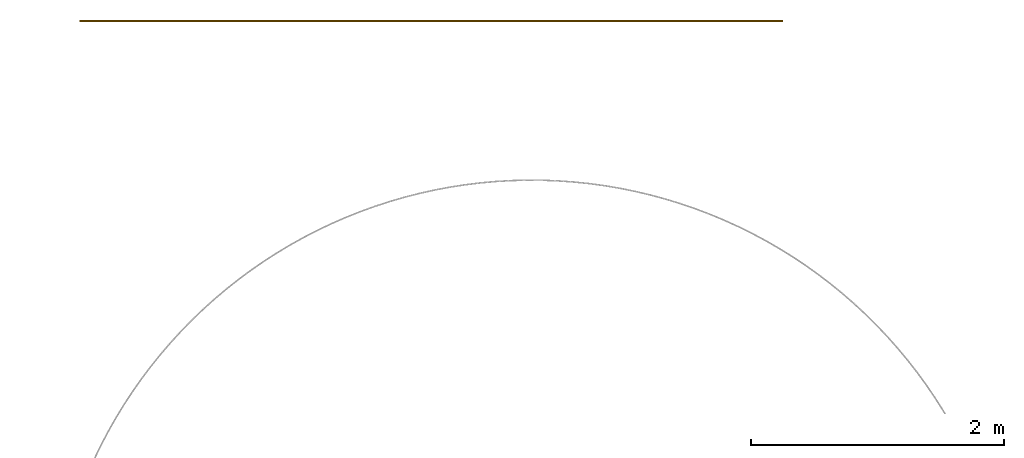
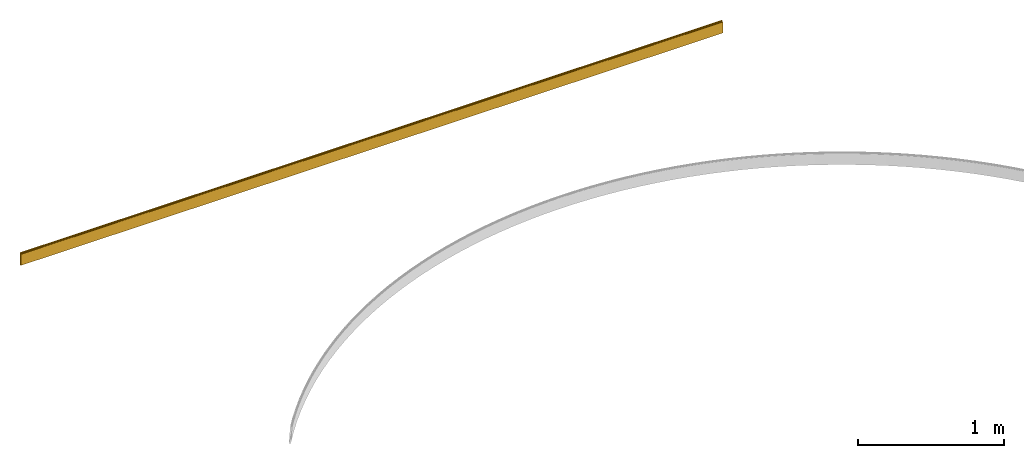
# One storey, part 2 of 2: 1 covering.
"""IFC2X3 building model written with IfcOpenShell, lengths in feet."""

from ifc_helpers import new_model, entity, si_unit, converted_unit, derived_unit, money_unit, direction, frame, frame_2d, origin_with_axes, place, context, subcontext, project, spatial, polyline, circle_curve, parameter, trimmed, segment, composite_curve, outline, extrude, material, type_object, element, save


model = new_model("IFC2X3")

# Units and contexts
model_context = context("Model", 3, precision=1e-05, world=origin_with_axes(), true_north=direction((0.0, 1.0)))
body_context = subcontext(model_context, "Body", "Model", "MODEL_VIEW", scale=1.0)
ifc_project = project(units=[converted_unit("LENGTHUNIT", "foot", entity("IfcReal", 30.48), si_unit("LENGTHUNIT", "METRE", prefix="CENTI"), dimensions=[1, 0, 0, 0, 0, 0, 0]), si_unit("AREAUNIT", "SQUARE_METRE"), si_unit("VOLUMEUNIT", "CUBIC_METRE"), si_unit("ABSORBEDDOSEUNIT", "GRAY"), si_unit("AMOUNTOFSUBSTANCEUNIT", "MOLE"), si_unit("DOSEEQUIVALENTUNIT", "SIEVERT"), si_unit("ELECTRICCAPACITANCEUNIT", "FARAD"), si_unit("ELECTRICCHARGEUNIT", "COULOMB"), si_unit("ELECTRICCONDUCTANCEUNIT", "SIEMENS"), si_unit("ELECTRICCURRENTUNIT", "AMPERE"), si_unit("ELECTRICRESISTANCEUNIT", "OHM"), si_unit("ELECTRICVOLTAGEUNIT", "VOLT"), si_unit("ENERGYUNIT", "JOULE"), si_unit("FORCEUNIT", "NEWTON"), si_unit("FREQUENCYUNIT", "HERTZ"), si_unit("ILLUMINANCEUNIT", "LUX"), si_unit("INDUCTANCEUNIT", "HENRY"), si_unit("LUMINOUSFLUXUNIT", "LUMEN"), si_unit("LUMINOUSINTENSITYUNIT", "CANDELA"), si_unit("MAGNETICFLUXDENSITYUNIT", "TESLA"), si_unit("MAGNETICFLUXUNIT", "WEBER"), si_unit("MASSUNIT", "GRAM"), converted_unit("PLANEANGLEUNIT", "degree", entity("IfcReal", 0.0174532925199433), si_unit("PLANEANGLEUNIT", "RADIAN"), dimensions=[0, 0, 0, 0, 0, 0, 0]), si_unit("POWERUNIT", "WATT"), si_unit("PRESSUREUNIT", "PASCAL"), si_unit("RADIOACTIVITYUNIT", "BECQUEREL"), si_unit("SOLIDANGLEUNIT", "STERADIAN"), si_unit("THERMODYNAMICTEMPERATUREUNIT", "KELVIN"), si_unit("TIMEUNIT", "SECOND"), derived_unit("ACCELERATIONUNIT", [(converted_unit("LENGTHUNIT", "foot", entity("IfcReal", 30.48), si_unit("LENGTHUNIT", "METRE", prefix="CENTI"), dimensions=[1, 0, 0, 0, 0, 0, 0]), 1), (si_unit("TIMEUNIT", "SECOND"), -2)]), derived_unit("ANGULARVELOCITYUNIT", [(converted_unit("PLANEANGLEUNIT", "degree", entity("IfcReal", 0.0174532925199433), si_unit("PLANEANGLEUNIT", "RADIAN"), dimensions=[0, 0, 0, 0, 0, 0, 0]), 1), (si_unit("TIMEUNIT", "SECOND"), -1)]), derived_unit("CURVATUREUNIT", [(converted_unit("PLANEANGLEUNIT", "degree", entity("IfcReal", 0.0174532925199433), si_unit("PLANEANGLEUNIT", "RADIAN"), dimensions=[0, 0, 0, 0, 0, 0, 0]), 1), (converted_unit("LENGTHUNIT", "foot", entity("IfcReal", 30.48), si_unit("LENGTHUNIT", "METRE", prefix="CENTI"), dimensions=[1, 0, 0, 0, 0, 0, 0]), -1)]), derived_unit("DYNAMICVISCOSITYUNIT", [(si_unit("PRESSUREUNIT", "PASCAL"), 1), (si_unit("TIMEUNIT", "SECOND"), 1)]), derived_unit("HEATFLUXDENSITYUNIT", [(si_unit("POWERUNIT", "WATT"), 1), (converted_unit("LENGTHUNIT", "foot", entity("IfcReal", 30.48), si_unit("LENGTHUNIT", "METRE", prefix="CENTI"), dimensions=[1, 0, 0, 0, 0, 0, 0]), -2)]), derived_unit("HEATINGVALUEUNIT", [(si_unit("ENERGYUNIT", "JOULE"), 1), (si_unit("MASSUNIT", "GRAM"), -1)]), derived_unit("INTEGERCOUNTRATEUNIT", [(si_unit("TIMEUNIT", "SECOND"), -1)]), derived_unit("IONCONCENTRATIONUNIT", [(si_unit("MASSUNIT", "GRAM"), 1), (si_unit("VOLUMEUNIT", "CUBIC_METRE"), -1)]), derived_unit("ISOTHERMALMOISTURECAPACITYUNIT", [(si_unit("VOLUMEUNIT", "CUBIC_METRE"), 1), (si_unit("MASSUNIT", "GRAM"), -1)]), derived_unit("KINEMATICVISCOSITYUNIT", [(si_unit("AREAUNIT", "SQUARE_METRE"), 1), (si_unit("TIMEUNIT", "SECOND"), -1)]), derived_unit("LINEARFORCEUNIT", [(si_unit("FORCEUNIT", "NEWTON"), 1), (converted_unit("LENGTHUNIT", "foot", entity("IfcReal", 30.48), si_unit("LENGTHUNIT", "METRE", prefix="CENTI"), dimensions=[1, 0, 0, 0, 0, 0, 0]), -1)]), derived_unit("LINEARMOMENTUNIT", [(si_unit("FORCEUNIT", "NEWTON"), 1), (converted_unit("LENGTHUNIT", "foot", entity("IfcReal", 30.48), si_unit("LENGTHUNIT", "METRE", prefix="CENTI"), dimensions=[1, 0, 0, 0, 0, 0, 0]), -1)]), derived_unit("LINEARSTIFFNESSUNIT", [(si_unit("FORCEUNIT", "NEWTON"), 1), (converted_unit("LENGTHUNIT", "foot", entity("IfcReal", 30.48), si_unit("LENGTHUNIT", "METRE", prefix="CENTI"), dimensions=[1, 0, 0, 0, 0, 0, 0]), -1)]), derived_unit("LINEARVELOCITYUNIT", [(converted_unit("LENGTHUNIT", "foot", entity("IfcReal", 30.48), si_unit("LENGTHUNIT", "METRE", prefix="CENTI"), dimensions=[1, 0, 0, 0, 0, 0, 0]), 1), (si_unit("TIMEUNIT", "SECOND"), -1)]), derived_unit("LUMINOUSINTENSITYDISTRIBUTIONUNIT", [(si_unit("LUMINOUSINTENSITYUNIT", "CANDELA"), 1), (si_unit("LUMINOUSFLUXUNIT", "LUMEN"), -1)]), derived_unit("MASSDENSITYUNIT", [(si_unit("MASSUNIT", "GRAM"), 1), (si_unit("VOLUMEUNIT", "CUBIC_METRE"), -1)]), derived_unit("MASSFLOWRATEUNIT", [(si_unit("MASSUNIT", "GRAM"), 1), (si_unit("TIMEUNIT", "SECOND"), -1)]), derived_unit("MASSPERLENGTHUNIT", [(si_unit("MASSUNIT", "GRAM"), 1), (converted_unit("LENGTHUNIT", "foot", entity("IfcReal", 30.48), si_unit("LENGTHUNIT", "METRE", prefix="CENTI"), dimensions=[1, 0, 0, 0, 0, 0, 0]), -1)]), derived_unit("MODULUSOFELASTICITYUNIT", [(si_unit("FORCEUNIT", "NEWTON"), 1), (si_unit("AREAUNIT", "SQUARE_METRE"), -1)]), derived_unit("MODULUSOFLINEARSUBGRADEREACTIONUNIT", [(si_unit("FORCEUNIT", "NEWTON"), 1), (converted_unit("LENGTHUNIT", "foot", entity("IfcReal", 30.48), si_unit("LENGTHUNIT", "METRE", prefix="CENTI"), dimensions=[1, 0, 0, 0, 0, 0, 0]), -2)]), derived_unit("MODULUSOFROTATIONALSUBGRADEREACTIONUNIT", [(si_unit("FORCEUNIT", "NEWTON"), 1), (converted_unit("LENGTHUNIT", "foot", entity("IfcReal", 30.48), si_unit("LENGTHUNIT", "METRE", prefix="CENTI"), dimensions=[1, 0, 0, 0, 0, 0, 0]), 1)]), derived_unit("MODULUSOFSUBGRADEREACTIONUNIT", [(si_unit("FORCEUNIT", "NEWTON"), 1), (si_unit("VOLUMEUNIT", "CUBIC_METRE"), -1)]), derived_unit("MOISTUREDIFFUSIVITYUNIT", [(si_unit("VOLUMEUNIT", "CUBIC_METRE"), 1), (si_unit("TIMEUNIT", "SECOND"), -1)]), derived_unit("MOLECULARWEIGHTUNIT", [(si_unit("MASSUNIT", "GRAM"), 1), (si_unit("AMOUNTOFSUBSTANCEUNIT", "MOLE"), -1)]), derived_unit("PLANARFORCEUNIT", [(si_unit("FORCEUNIT", "NEWTON"), 1), (converted_unit("LENGTHUNIT", "foot", entity("IfcReal", 30.48), si_unit("LENGTHUNIT", "METRE", prefix="CENTI"), dimensions=[1, 0, 0, 0, 0, 0, 0]), -2)]), derived_unit("ROTATIONALFREQUENCYUNIT", [(si_unit("TIMEUNIT", "SECOND"), -1)]), derived_unit("ROTATIONALMASSUNIT", [(si_unit("MASSUNIT", "GRAM"), 1), (converted_unit("LENGTHUNIT", "foot", entity("IfcReal", 30.48), si_unit("LENGTHUNIT", "METRE", prefix="CENTI"), dimensions=[1, 0, 0, 0, 0, 0, 0]), 2)]), derived_unit("ROTATIONALSTIFFNESSUNIT", [(si_unit("FORCEUNIT", "NEWTON"), 1), (converted_unit("LENGTHUNIT", "foot", entity("IfcReal", 30.48), si_unit("LENGTHUNIT", "METRE", prefix="CENTI"), dimensions=[1, 0, 0, 0, 0, 0, 0]), 1), (converted_unit("PLANEANGLEUNIT", "degree", entity("IfcReal", 0.0174532925199433), si_unit("PLANEANGLEUNIT", "RADIAN"), dimensions=[0, 0, 0, 0, 0, 0, 0]), -1)]), derived_unit("SECTIONAREAINTEGRALUNIT", [(converted_unit("LENGTHUNIT", "foot", entity("IfcReal", 30.48), si_unit("LENGTHUNIT", "METRE", prefix="CENTI"), dimensions=[1, 0, 0, 0, 0, 0, 0]), 5)]), derived_unit("SECTIONMODULUSUNIT", [(converted_unit("LENGTHUNIT", "foot", entity("IfcReal", 30.48), si_unit("LENGTHUNIT", "METRE", prefix="CENTI"), dimensions=[1, 0, 0, 0, 0, 0, 0]), 3)]), derived_unit("SHEARMODULUSUNIT", [(si_unit("FORCEUNIT", "NEWTON"), 1), (si_unit("AREAUNIT", "SQUARE_METRE"), -1)]), derived_unit("SOUNDPOWERUNIT", [(si_unit("ENERGYUNIT", "JOULE"), 1), (si_unit("TIMEUNIT", "SECOND"), -1)]), derived_unit("SPECIFICHEATCAPACITYUNIT", [(si_unit("FORCEUNIT", "NEWTON"), 1), (si_unit("MASSUNIT", "GRAM"), -1), (si_unit("THERMODYNAMICTEMPERATUREUNIT", "KELVIN"), -1)]), derived_unit("TEMPERATUREGRADIENTUNIT", [(si_unit("THERMODYNAMICTEMPERATUREUNIT", "KELVIN"), 1), (converted_unit("LENGTHUNIT", "foot", entity("IfcReal", 30.48), si_unit("LENGTHUNIT", "METRE", prefix="CENTI"), dimensions=[1, 0, 0, 0, 0, 0, 0]), -1)]), derived_unit("THERMALADMITTANCEUNIT", [(si_unit("POWERUNIT", "WATT"), 1), (si_unit("AREAUNIT", "SQUARE_METRE"), -1), (si_unit("THERMODYNAMICTEMPERATUREUNIT", "KELVIN"), -1)]), derived_unit("THERMALCONDUCTANCEUNIT", [(si_unit("POWERUNIT", "WATT"), 1), (converted_unit("LENGTHUNIT", "foot", entity("IfcReal", 30.48), si_unit("LENGTHUNIT", "METRE", prefix="CENTI"), dimensions=[1, 0, 0, 0, 0, 0, 0]), -1), (si_unit("THERMODYNAMICTEMPERATUREUNIT", "KELVIN"), -1)]), derived_unit("THERMALEXPANSIONCOEFFICIENTUNIT", [(si_unit("THERMODYNAMICTEMPERATUREUNIT", "KELVIN"), -1)]), derived_unit("THERMALRESISTANCEUNIT", [(si_unit("AREAUNIT", "SQUARE_METRE"), 1), (si_unit("POWERUNIT", "WATT"), -1)]), derived_unit("THERMALTRANSMITTANCEUNIT", [(si_unit("POWERUNIT", "WATT"), 1), (si_unit("AREAUNIT", "SQUARE_METRE"), -1), (si_unit("THERMODYNAMICTEMPERATUREUNIT", "KELVIN"), -1)]), derived_unit("TORQUEUNIT", [(si_unit("FORCEUNIT", "NEWTON"), 1), (converted_unit("LENGTHUNIT", "foot", entity("IfcReal", 30.48), si_unit("LENGTHUNIT", "METRE", prefix="CENTI"), dimensions=[1, 0, 0, 0, 0, 0, 0]), 1)]), derived_unit("VAPORPERMEABILITYUNIT", [(si_unit("MASSUNIT", "GRAM"), 1), (si_unit("TIMEUNIT", "SECOND"), -1)]), derived_unit("VOLUMETRICFLOWRATEUNIT", [(si_unit("VOLUMEUNIT", "CUBIC_METRE"), 1), (si_unit("TIMEUNIT", "SECOND"), -1)]), derived_unit("WARPINGCONSTANTUNIT", [(converted_unit("LENGTHUNIT", "foot", entity("IfcReal", 30.48), si_unit("LENGTHUNIT", "METRE", prefix="CENTI"), dimensions=[1, 0, 0, 0, 0, 0, 0]), 6)]), derived_unit("WARPINGMOMENTUNIT", [(si_unit("FORCEUNIT", "NEWTON"), 1), (converted_unit("LENGTHUNIT", "foot", entity("IfcReal", 30.48), si_unit("LENGTHUNIT", "METRE", prefix="CENTI"), dimensions=[1, 0, 0, 0, 0, 0, 0]), 2)]), money_unit("USD")], contexts=[model_context])

# Site, building, storey
site_placement = place(None, origin_with_axes())
site = spatial("IfcSite", under=ifc_project, at=site_placement, CompositionType="ELEMENT")
building_placement = place(site_placement, origin_with_axes())
building = spatial("IfcBuilding", under=site, at=building_placement, Name="Bldg 1", CompositionType="ELEMENT")
storey_placement = place(building_placement, origin_with_axes())
storey = spatial("IfcBuildingStorey", under=building, at=storey_placement, Name="Floor 1", CompositionType="ELEMENT", Elevation=0.0)

# Covering
ifc_material = material(Name="WallBase")
covering_type = type_object("IfcCoveringType", Name="Base Molding", PredefinedType="NOTDEFINED")
covering_placement = place(storey_placement, frame((-18.392305, 35.977421, 0.323846), z_axis=(1.0, 0.0, 0.0), x_axis=(0.0, -1.0, 0.0)))
element("IfcCovering", 1, at=covering_placement, inside=storey, type_object=covering_type, material=ifc_material, Name="Base Molding", ObjectType="Base Molding", PredefinedType="NOTDEFINED", context=body_context, shape_type="SweptSolid", body=[
    extrude(outline(composite_curve([segment(trimmed(circle_curve(frame_2d((0.0, 0.019235), x_axis=(1.0, 0.0)), 0.019235), [parameter(270.0)], [parameter(360.0)], True, "PARAMETER"), True, "CONTINUOUS"), segment(polyline([(0.019235, 0.019235), (0.028266, 0.019235)]), True, "CONTINUOUS"), segment(polyline([(0.028266, 0.019235), (0.028266, 0.323846)]), True, "CONTINUOUS"), segment(polyline([(0.028266, 0.323846), (-0.013401, 0.323846)]), True, "CONTINUOUS"), segment(polyline([(-0.013401, 0.323846), (-0.013401, -0.009487)]), True, "CONTINUOUS"), segment(polyline([(-0.013401, -0.009487), (0.0, -0.009487)]), True, "CONTINUOUS"), segment(polyline([(0.0, -0.009487), (0.0, 0.0)]), True, "CONTINUOUS")], self_intersect=False)), origin_with_axes(), (0.0, 0.0, 1.0), 18.257924),
])

save(model, "model.ifc")
